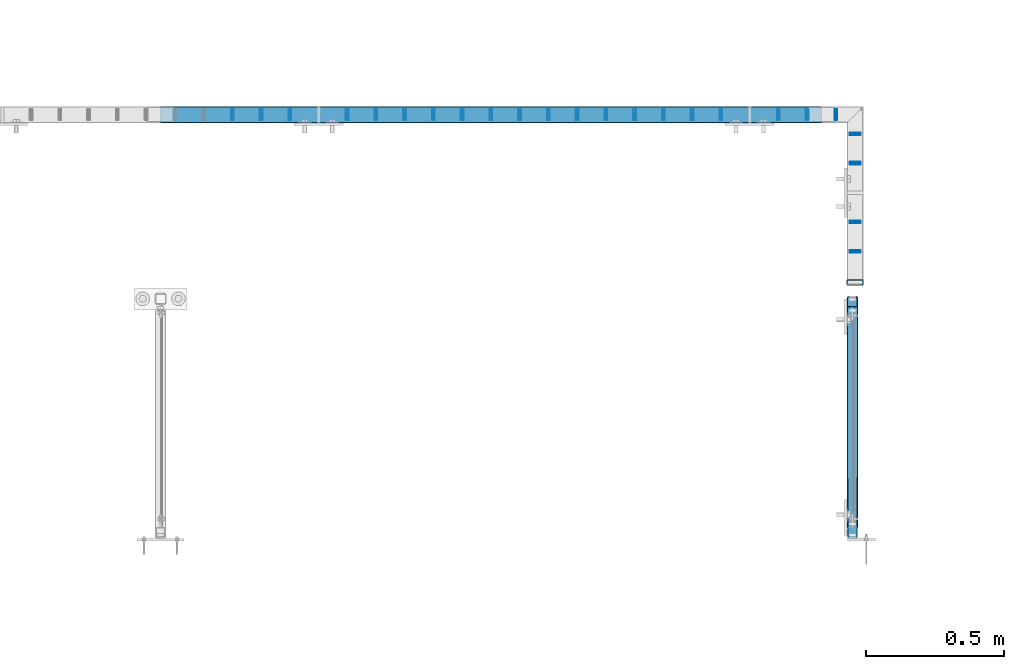
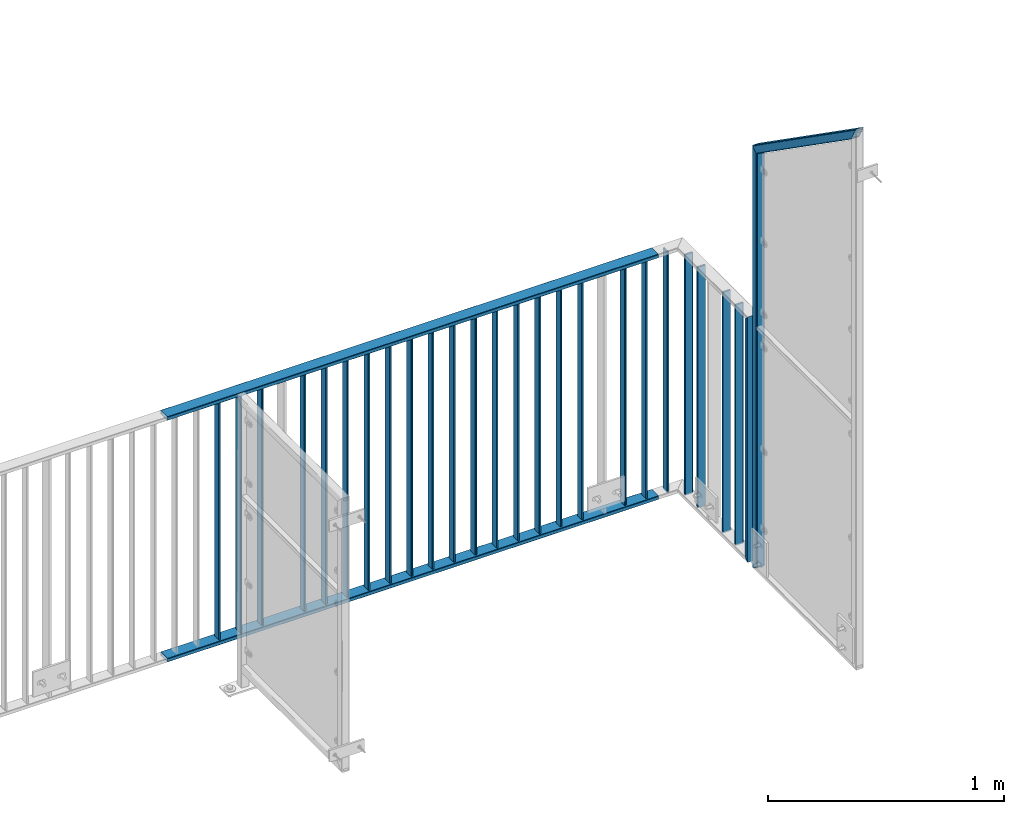
# One storey, part 28 of 156: 29 beams, 3 elements without a shape of their own.
"""IFC2X3 building model written with IfcOpenShell, lengths in millimetres."""

from ifc_helpers import new_model, si_unit, frame, origin_with_axes, origin_2d_with_axis, place, context, subcontext, project, spatial, hollow_rectangle, extrude, clip, halfspace, material, type_object, element, aggregate, save


model = new_model("IFC2X3")

# Units and contexts
model_context = context("Model", 3, precision=1e-05, world=origin_with_axes())
body_context = subcontext(model_context, "Body", "Model", "MODEL_VIEW")
ifc_project = project(units=[si_unit("LENGTHUNIT", "METRE", prefix="MILLI"), si_unit("AREAUNIT", "SQUARE_METRE"), si_unit("VOLUMEUNIT", "CUBIC_METRE"), si_unit("MASSUNIT", "GRAM", prefix="KILO"), si_unit("TIMEUNIT", "SECOND"), si_unit("PLANEANGLEUNIT", "RADIAN"), si_unit("SOLIDANGLEUNIT", "STERADIAN"), si_unit("THERMODYNAMICTEMPERATUREUNIT", "DEGREE_CELSIUS"), si_unit("LUMINOUSINTENSITYUNIT", "LUMEN")], contexts=[model_context])

# Site, building, storey
site_placement = place(None, origin_with_axes())
site = spatial("IfcSite", under=ifc_project, at=site_placement, CompositionType="ELEMENT")
building_placement = place(site_placement, origin_with_axes())
building = spatial("IfcBuilding", under=site, at=building_placement, Name="Undefined", CompositionType="ELEMENT")
storey_placement = place(building_placement, origin_with_axes())
storey = spatial("IfcBuildingStorey", under=building, at=storey_placement, Name="Undefined", CompositionType="ELEMENT", Elevation=0.0)

# Assembly, beam
assembly_1_placement = place(storey_placement, origin_with_axes())
assembly_1 = element("IfcElementAssembly", 1, at=assembly_1_placement, inside=storey, AssemblyPlace="NOTDEFINED", PredefinedType="RIGID_FRAME")
ifc_material = material(Name="STEEL/S235JR")
beam_type_1 = type_object("IfcBeamType", Name="K60/20/2", PredefinedType="NOTDEFINED")
beam_1_placement = place(assembly_1_placement, frame((36402.6741455078, 21657.9919947282, 2740.0), z_axis=(0.0, -1.0, 0.0), x_axis=(-1.0, 0.0, 0.0)))
beam_1 = element("IfcBeam", 2, at=beam_1_placement, type_object=beam_type_1, material=ifc_material, ObjectType="K60/20/2", context=body_context, shape_type="SweptSolid", body=[
    extrude(hollow_rectangle(XDim=20.0, YDim=60.0, WallThickness=2.0, InnerFilletRadius=2.0, OuterFilletRadius=4.0, at=origin_2d_with_axis()), frame((2402.72054931641, 0.0, 0.0), z_axis=(-1.0, 0.0, 0.0), x_axis=(0.0, -1.0, 0.0)), (0.0, 0.0, 1.0), 2402.72),
])

assembly_2_placement = place(storey_placement, origin_with_axes())
assembly_2 = element("IfcElementAssembly", 3, at=assembly_2_placement, inside=storey, AssemblyPlace="NOTDEFINED", PredefinedType="RIGID_FRAME")
beam_2_placement = place(assembly_2_placement, frame((36524.9961242676, 21048.0016473224, 4000.0), z_axis=(-1.0, 0.0, 0.0), x_axis=(0.0, 0.0, -1.0)))
beam_2 = element("IfcBeam", 4, at=beam_2_placement, type_object=beam_type_1, material=ifc_material, ObjectType="K60/20/2", context=body_context, shape_type="Clipping", body=[
    clip(clip(extrude(hollow_rectangle(XDim=20.0, YDim=60.0, WallThickness=2.0, InnerFilletRadius=2.0, OuterFilletRadius=4.0, at=origin_2d_with_axis()), frame((1280.2, 0.0, 0.0), z_axis=(-1.0, 0.0, 0.0), x_axis=(0.0, -1.0, 0.0)), (0.0, 0.0, 1.0), 1290.4), halfspace(frame((1270.0, 10.0, 0.0), z_axis=(0.707106781186548, -0.707106781186548, 0.0), x_axis=(0.0, 0.0, -1.0)), False)), halfspace(frame((20.0, -10.0, 0.0), z_axis=(-0.707106781186548, -0.707106781186548, 0.0), x_axis=(0.0, 0.0, -1.0)), False)),
])

# Beam
beam_3_placement = place(assembly_1_placement, frame((36402.6741455078, 21657.9919947282, 3990.0), z_axis=(0.0, -1.0, 0.0), x_axis=(-1.0, 0.0, 0.0)))
beam_3 = element("IfcBeam", 5, at=beam_3_placement, type_object=beam_type_1, material=ifc_material, ObjectType="K60/20/2", context=body_context, shape_type="SweptSolid", body=[
    extrude(hollow_rectangle(XDim=20.0, YDim=60.0, WallThickness=2.0, InnerFilletRadius=2.0, OuterFilletRadius=4.0, at=origin_2d_with_axis()), frame((2402.72054931641, 0.0, 0.0), z_axis=(-1.0, 0.0, 0.0), x_axis=(0.0, -1.0, 0.0)), (0.0, 0.0, 1.0), 2402.72),
])

beam_type_2 = type_object("IfcBeamType", Name="K40/10/1.5", PredefinedType="NOTDEFINED")
beam_4_placement = place(assembly_1_placement, frame((34679.0085961914, 21657.9919947282, 3980.00000000003), z_axis=(0.0, -1.0, 0.0), x_axis=(0.0, 0.0, -1.0)))
beam_4 = element("IfcBeam", 6, at=beam_4_placement, type_object=beam_type_2, material=ifc_material, ObjectType="K40/10/1.5", context=body_context, shape_type="Clipping", body=[
    clip(clip(extrude(hollow_rectangle(XDim=10.0, YDim=40.0, WallThickness=1.5, InnerFilletRadius=1.5, OuterFilletRadius=3.0, at=origin_2d_with_axis()), frame((1237.00000000003, 0.0, 0.0), z_axis=(-1.0, 0.0, 0.0), x_axis=(0.0, -1.0, 0.0)), (0.0, 0.0, 1.0), 1244.0), halfspace(frame((1237.00000000003, 4.34248751949781, 47.3810900558092), z_axis=(1.0, 0.0, 0.0), x_axis=(0.0, -0.768354814194188, -0.640024124158313)), False)), halfspace(frame((-6.99999999997453, -4.34248751950508, 47.3810900558092), z_axis=(-1.0, 0.0, 0.0), x_axis=(0.0, 0.7683548141934, -0.640024124159258)), False)),
])

beam_5_placement = place(assembly_1_placement, frame((36246.0585961914, 21657.9919947282, 3980.00000000003), z_axis=(0.0, -1.0, 0.0), x_axis=(0.0, 0.0, -1.0)))
beam_5 = element("IfcBeam", 7, at=beam_5_placement, type_object=beam_type_2, material=ifc_material, ObjectType="K40/10/1.5", context=body_context, shape_type="Clipping", body=[
    clip(clip(extrude(hollow_rectangle(XDim=10.0, YDim=40.0, WallThickness=1.5, InnerFilletRadius=1.5, OuterFilletRadius=3.0, at=origin_2d_with_axis()), frame((1237.00000000003, 0.0, 0.0), z_axis=(-1.0, 0.0, 0.0), x_axis=(0.0, -1.0, 0.0)), (0.0, 0.0, 1.0), 1244.0), halfspace(frame((1237.00000000003, 4.34248751949781, 47.3810900558092), z_axis=(1.0, 0.0, 0.0), x_axis=(0.0, -0.768354814194188, -0.640024124158313)), False)), halfspace(frame((-6.99999999997453, -4.34248751950508, 47.3810900558092), z_axis=(-1.0, 0.0, 0.0), x_axis=(0.0, 0.7683548141934, -0.640024124159258)), False)),
])

beam_6_placement = place(assembly_1_placement, frame((34261.1285961914, 21657.9919947282, 3980.00000000003), z_axis=(0.0, -1.0, 0.0), x_axis=(0.0, 0.0, -1.0)))
beam_6 = element("IfcBeam", 8, at=beam_6_placement, type_object=beam_type_2, material=ifc_material, ObjectType="K40/10/1.5", context=body_context, shape_type="Clipping", body=[
    clip(clip(extrude(hollow_rectangle(XDim=10.0, YDim=40.0, WallThickness=1.5, InnerFilletRadius=1.5, OuterFilletRadius=3.0, at=origin_2d_with_axis()), frame((1237.00000000003, 0.0, 0.0), z_axis=(-1.0, 0.0, 0.0), x_axis=(0.0, -1.0, 0.0)), (0.0, 0.0, 1.0), 1244.0), halfspace(frame((1237.00000000003, 4.34248751949781, 47.3810900558092), z_axis=(1.0, 0.0, 0.0), x_axis=(0.0, -0.768354814194188, -0.640024124158313)), False)), halfspace(frame((-6.99999999997453, -4.34248751950508, 47.3810900558092), z_axis=(-1.0, 0.0, 0.0), x_axis=(0.0, 0.7683548141934, -0.640024124159258)), False)),
])

beam_7_placement = place(assembly_1_placement, frame((34365.5985961914, 21657.9919947282, 3980.00000000003), z_axis=(0.0, -1.0, 0.0), x_axis=(0.0, 0.0, -1.0)))
beam_7 = element("IfcBeam", 9, at=beam_7_placement, type_object=beam_type_2, material=ifc_material, ObjectType="K40/10/1.5", context=body_context, shape_type="Clipping", body=[
    clip(clip(extrude(hollow_rectangle(XDim=10.0, YDim=40.0, WallThickness=1.5, InnerFilletRadius=1.5, OuterFilletRadius=3.0, at=origin_2d_with_axis()), frame((1237.00000000003, 0.0, 0.0), z_axis=(-1.0, 0.0, 0.0), x_axis=(0.0, -1.0, 0.0)), (0.0, 0.0, 1.0), 1244.0), halfspace(frame((1237.00000000003, 4.34248751949781, 47.3810900558092), z_axis=(1.0, 0.0, 0.0), x_axis=(0.0, -0.768354814194188, -0.640024124158313)), False)), halfspace(frame((-6.99999999997453, -4.34248751950508, 47.3810900558092), z_axis=(-1.0, 0.0, 0.0), x_axis=(0.0, 0.7683548141934, -0.640024124159258)), False)),
])

beam_8_placement = place(assembly_1_placement, frame((34470.0685961914, 21657.9919947282, 3980.00000000003), z_axis=(0.0, -1.0, 0.0), x_axis=(0.0, 0.0, -1.0)))
beam_8 = element("IfcBeam", 10, at=beam_8_placement, type_object=beam_type_2, material=ifc_material, ObjectType="K40/10/1.5", context=body_context, shape_type="Clipping", body=[
    clip(clip(extrude(hollow_rectangle(XDim=10.0, YDim=40.0, WallThickness=1.5, InnerFilletRadius=1.5, OuterFilletRadius=3.0, at=origin_2d_with_axis()), frame((1237.00000000003, 0.0, 0.0), z_axis=(-1.0, 0.0, 0.0), x_axis=(0.0, -1.0, 0.0)), (0.0, 0.0, 1.0), 1244.0), halfspace(frame((1237.00000000003, 4.34248751949781, 47.3810900558092), z_axis=(1.0, 0.0, 0.0), x_axis=(0.0, -0.768354814194188, -0.640024124158313)), False)), halfspace(frame((-6.99999999997453, -4.34248751950508, 47.3810900558092), z_axis=(-1.0, 0.0, 0.0), x_axis=(0.0, 0.7683548141934, -0.640024124159258)), False)),
])

beam_9_placement = place(assembly_1_placement, frame((34783.4785961914, 21657.9919947282, 3980.00000000003), z_axis=(0.0, -1.0, 0.0), x_axis=(0.0, 0.0, -1.0)))
beam_9 = element("IfcBeam", 11, at=beam_9_placement, type_object=beam_type_2, material=ifc_material, ObjectType="K40/10/1.5", context=body_context, shape_type="Clipping", body=[
    clip(clip(extrude(hollow_rectangle(XDim=10.0, YDim=40.0, WallThickness=1.5, InnerFilletRadius=1.5, OuterFilletRadius=3.0, at=origin_2d_with_axis()), frame((1237.00000000003, 0.0, 0.0), z_axis=(-1.0, 0.0, 0.0), x_axis=(0.0, -1.0, 0.0)), (0.0, 0.0, 1.0), 1244.0), halfspace(frame((1237.00000000003, 4.34248751949781, 47.3810900558092), z_axis=(1.0, 0.0, 0.0), x_axis=(0.0, -0.768354814194188, -0.640024124158313)), False)), halfspace(frame((-6.99999999997453, -4.34248751950508, 47.3810900558092), z_axis=(-1.0, 0.0, 0.0), x_axis=(0.0, 0.7683548141934, -0.640024124159258)), False)),
])

beam_10_placement = place(assembly_1_placement, frame((34887.9485961914, 21657.9919947282, 3980.00000000003), z_axis=(0.0, -1.0, 0.0), x_axis=(0.0, 0.0, -1.0)))
beam_10 = element("IfcBeam", 12, at=beam_10_placement, type_object=beam_type_2, material=ifc_material, ObjectType="K40/10/1.5", context=body_context, shape_type="Clipping", body=[
    clip(clip(extrude(hollow_rectangle(XDim=10.0, YDim=40.0, WallThickness=1.5, InnerFilletRadius=1.5, OuterFilletRadius=3.0, at=origin_2d_with_axis()), frame((1237.00000000003, 0.0, 0.0), z_axis=(-1.0, 0.0, 0.0), x_axis=(0.0, -1.0, 0.0)), (0.0, 0.0, 1.0), 1244.0), halfspace(frame((1237.00000000003, 4.34248751949781, 47.3810900558092), z_axis=(1.0, 0.0, 0.0), x_axis=(0.0, -0.768354814194188, -0.640024124158313)), False)), halfspace(frame((-6.99999999997453, -4.34248751950508, 47.3810900558092), z_axis=(-1.0, 0.0, 0.0), x_axis=(0.0, 0.7683548141934, -0.640024124159258)), False)),
])

beam_11_placement = place(assembly_1_placement, frame((34992.4185961914, 21657.9919947282, 3980.00000000003), z_axis=(0.0, -1.0, 0.0), x_axis=(0.0, 0.0, -1.0)))
beam_11 = element("IfcBeam", 13, at=beam_11_placement, type_object=beam_type_2, material=ifc_material, ObjectType="K40/10/1.5", context=body_context, shape_type="Clipping", body=[
    clip(clip(extrude(hollow_rectangle(XDim=10.0, YDim=40.0, WallThickness=1.5, InnerFilletRadius=1.5, OuterFilletRadius=3.0, at=origin_2d_with_axis()), frame((1237.00000000003, 0.0, 0.0), z_axis=(-1.0, 0.0, 0.0), x_axis=(0.0, -1.0, 0.0)), (0.0, 0.0, 1.0), 1244.0), halfspace(frame((1237.00000000003, 4.34248751949781, 47.3810900558092), z_axis=(1.0, 0.0, 0.0), x_axis=(0.0, -0.768354814194188, -0.640024124158313)), False)), halfspace(frame((-6.99999999997453, -4.34248751950508, 47.3810900558092), z_axis=(-1.0, 0.0, 0.0), x_axis=(0.0, 0.7683548141934, -0.640024124159258)), False)),
])

beam_12_placement = place(assembly_1_placement, frame((35096.8885961914, 21657.9919947282, 3980.00000000003), z_axis=(0.0, -1.0, 0.0), x_axis=(0.0, 0.0, -1.0)))
beam_12 = element("IfcBeam", 14, at=beam_12_placement, type_object=beam_type_2, material=ifc_material, ObjectType="K40/10/1.5", context=body_context, shape_type="Clipping", body=[
    clip(clip(extrude(hollow_rectangle(XDim=10.0, YDim=40.0, WallThickness=1.5, InnerFilletRadius=1.5, OuterFilletRadius=3.0, at=origin_2d_with_axis()), frame((1237.00000000003, 0.0, 0.0), z_axis=(-1.0, 0.0, 0.0), x_axis=(0.0, -1.0, 0.0)), (0.0, 0.0, 1.0), 1244.0), halfspace(frame((1237.00000000003, 4.34248751949781, 47.3810900558092), z_axis=(1.0, 0.0, 0.0), x_axis=(0.0, -0.768354814194188, -0.640024124158313)), False)), halfspace(frame((-6.99999999997453, -4.34248751950508, 47.3810900558092), z_axis=(-1.0, 0.0, 0.0), x_axis=(0.0, 0.7683548141934, -0.640024124159258)), False)),
])

beam_13_placement = place(assembly_1_placement, frame((35201.3585961914, 21657.9919947282, 3980.00000000003), z_axis=(0.0, -1.0, 0.0), x_axis=(0.0, 0.0, -1.0)))
beam_13 = element("IfcBeam", 15, at=beam_13_placement, type_object=beam_type_2, material=ifc_material, ObjectType="K40/10/1.5", context=body_context, shape_type="Clipping", body=[
    clip(clip(extrude(hollow_rectangle(XDim=10.0, YDim=40.0, WallThickness=1.5, InnerFilletRadius=1.5, OuterFilletRadius=3.0, at=origin_2d_with_axis()), frame((1237.00000000003, 0.0, 0.0), z_axis=(-1.0, 0.0, 0.0), x_axis=(0.0, -1.0, 0.0)), (0.0, 0.0, 1.0), 1244.0), halfspace(frame((1237.00000000003, 4.34248751949781, 47.3810900558092), z_axis=(1.0, 0.0, 0.0), x_axis=(0.0, -0.768354814194188, -0.640024124158313)), False)), halfspace(frame((-6.99999999997453, -4.34248751950508, 47.3810900558092), z_axis=(-1.0, 0.0, 0.0), x_axis=(0.0, 0.7683548141934, -0.640024124159258)), False)),
])

beam_14_placement = place(assembly_1_placement, frame((35305.8285961914, 21657.9919947282, 3980.00000000003), z_axis=(0.0, -1.0, 0.0), x_axis=(0.0, 0.0, -1.0)))
beam_14 = element("IfcBeam", 16, at=beam_14_placement, type_object=beam_type_2, material=ifc_material, ObjectType="K40/10/1.5", context=body_context, shape_type="Clipping", body=[
    clip(clip(extrude(hollow_rectangle(XDim=10.0, YDim=40.0, WallThickness=1.5, InnerFilletRadius=1.5, OuterFilletRadius=3.0, at=origin_2d_with_axis()), frame((1237.00000000003, 0.0, 0.0), z_axis=(-1.0, 0.0, 0.0), x_axis=(0.0, -1.0, 0.0)), (0.0, 0.0, 1.0), 1244.0), halfspace(frame((1237.00000000003, 4.34248751949781, 47.3810900558092), z_axis=(1.0, 0.0, 0.0), x_axis=(0.0, -0.768354814194188, -0.640024124158313)), False)), halfspace(frame((-6.99999999997453, -4.34248751950508, 47.3810900558092), z_axis=(-1.0, 0.0, 0.0), x_axis=(0.0, 0.7683548141934, -0.640024124159258)), False)),
])

beam_15_placement = place(assembly_1_placement, frame((35410.2985961914, 21657.9919947282, 3980.00000000003), z_axis=(0.0, -1.0, 0.0), x_axis=(0.0, 0.0, -1.0)))
beam_15 = element("IfcBeam", 17, at=beam_15_placement, type_object=beam_type_2, material=ifc_material, ObjectType="K40/10/1.5", context=body_context, shape_type="Clipping", body=[
    clip(clip(extrude(hollow_rectangle(XDim=10.0, YDim=40.0, WallThickness=1.5, InnerFilletRadius=1.5, OuterFilletRadius=3.0, at=origin_2d_with_axis()), frame((1237.00000000003, 0.0, 0.0), z_axis=(-1.0, 0.0, 0.0), x_axis=(0.0, -1.0, 0.0)), (0.0, 0.0, 1.0), 1244.0), halfspace(frame((1237.00000000003, 4.34248751949781, 47.3810900558092), z_axis=(1.0, 0.0, 0.0), x_axis=(0.0, -0.768354814194188, -0.640024124158313)), False)), halfspace(frame((-6.99999999997453, -4.34248751950508, 47.3810900558092), z_axis=(-1.0, 0.0, 0.0), x_axis=(0.0, 0.7683548141934, -0.640024124159258)), False)),
])

beam_16_placement = place(assembly_1_placement, frame((35514.7685961914, 21657.9919947282, 3980.00000000003), z_axis=(0.0, -1.0, 0.0), x_axis=(0.0, 0.0, -1.0)))
beam_16 = element("IfcBeam", 18, at=beam_16_placement, type_object=beam_type_2, material=ifc_material, ObjectType="K40/10/1.5", context=body_context, shape_type="Clipping", body=[
    clip(clip(extrude(hollow_rectangle(XDim=10.0, YDim=40.0, WallThickness=1.5, InnerFilletRadius=1.5, OuterFilletRadius=3.0, at=origin_2d_with_axis()), frame((1237.00000000003, 0.0, 0.0), z_axis=(-1.0, 0.0, 0.0), x_axis=(0.0, -1.0, 0.0)), (0.0, 0.0, 1.0), 1244.0), halfspace(frame((1237.00000000003, 4.34248751949781, 47.3810900558092), z_axis=(1.0, 0.0, 0.0), x_axis=(0.0, -0.768354814194188, -0.640024124158313)), False)), halfspace(frame((-6.99999999997453, -4.34248751950508, 47.3810900558092), z_axis=(-1.0, 0.0, 0.0), x_axis=(0.0, 0.7683548141934, -0.640024124159258)), False)),
])

beam_17_placement = place(assembly_1_placement, frame((35619.2385961914, 21657.9919947282, 3980.00000000003), z_axis=(0.0, -1.0, 0.0), x_axis=(0.0, 0.0, -1.0)))
beam_17 = element("IfcBeam", 19, at=beam_17_placement, type_object=beam_type_2, material=ifc_material, ObjectType="K40/10/1.5", context=body_context, shape_type="Clipping", body=[
    clip(clip(extrude(hollow_rectangle(XDim=10.0, YDim=40.0, WallThickness=1.5, InnerFilletRadius=1.5, OuterFilletRadius=3.0, at=origin_2d_with_axis()), frame((1237.00000000003, 0.0, 0.0), z_axis=(-1.0, 0.0, 0.0), x_axis=(0.0, -1.0, 0.0)), (0.0, 0.0, 1.0), 1244.0), halfspace(frame((1237.00000000003, 4.34248751949781, 47.3810900558092), z_axis=(1.0, 0.0, 0.0), x_axis=(0.0, -0.768354814194188, -0.640024124158313)), False)), halfspace(frame((-6.99999999997453, -4.34248751950508, 47.3810900558092), z_axis=(-1.0, 0.0, 0.0), x_axis=(0.0, 0.7683548141934, -0.640024124159258)), False)),
])

beam_18_placement = place(assembly_1_placement, frame((35723.7085961914, 21657.9919947282, 3980.00000000003), z_axis=(0.0, -1.0, 0.0), x_axis=(0.0, 0.0, -1.0)))
beam_18 = element("IfcBeam", 20, at=beam_18_placement, type_object=beam_type_2, material=ifc_material, ObjectType="K40/10/1.5", context=body_context, shape_type="Clipping", body=[
    clip(clip(extrude(hollow_rectangle(XDim=10.0, YDim=40.0, WallThickness=1.5, InnerFilletRadius=1.5, OuterFilletRadius=3.0, at=origin_2d_with_axis()), frame((1237.00000000003, 0.0, 0.0), z_axis=(-1.0, 0.0, 0.0), x_axis=(0.0, -1.0, 0.0)), (0.0, 0.0, 1.0), 1244.0), halfspace(frame((1237.00000000003, 4.34248751949781, 47.3810900558092), z_axis=(1.0, 0.0, 0.0), x_axis=(0.0, -0.768354814194188, -0.640024124158313)), False)), halfspace(frame((-6.99999999997453, -4.34248751950508, 47.3810900558092), z_axis=(-1.0, 0.0, 0.0), x_axis=(0.0, 0.7683548141934, -0.640024124159258)), False)),
])

beam_19_placement = place(assembly_1_placement, frame((35828.1785961914, 21657.9919947282, 3980.00000000003), z_axis=(0.0, -1.0, 0.0), x_axis=(0.0, 0.0, -1.0)))
beam_19 = element("IfcBeam", 21, at=beam_19_placement, type_object=beam_type_2, material=ifc_material, ObjectType="K40/10/1.5", context=body_context, shape_type="Clipping", body=[
    clip(clip(extrude(hollow_rectangle(XDim=10.0, YDim=40.0, WallThickness=1.5, InnerFilletRadius=1.5, OuterFilletRadius=3.0, at=origin_2d_with_axis()), frame((1237.00000000003, 0.0, 0.0), z_axis=(-1.0, 0.0, 0.0), x_axis=(0.0, -1.0, 0.0)), (0.0, 0.0, 1.0), 1244.0), halfspace(frame((1237.00000000003, 4.34248751949781, 47.3810900558092), z_axis=(1.0, 0.0, 0.0), x_axis=(0.0, -0.768354814194188, -0.640024124158313)), False)), halfspace(frame((-6.99999999997453, -4.34248751950508, 47.3810900558092), z_axis=(-1.0, 0.0, 0.0), x_axis=(0.0, 0.7683548141934, -0.640024124159258)), False)),
])

beam_20_placement = place(assembly_1_placement, frame((35932.6485961914, 21657.9919947282, 3980.00000000003), z_axis=(0.0, -1.0, 0.0), x_axis=(0.0, 0.0, -1.0)))
beam_20 = element("IfcBeam", 22, at=beam_20_placement, type_object=beam_type_2, material=ifc_material, ObjectType="K40/10/1.5", context=body_context, shape_type="Clipping", body=[
    clip(clip(extrude(hollow_rectangle(XDim=10.0, YDim=40.0, WallThickness=1.5, InnerFilletRadius=1.5, OuterFilletRadius=3.0, at=origin_2d_with_axis()), frame((1237.00000000003, 0.0, 0.0), z_axis=(-1.0, 0.0, 0.0), x_axis=(0.0, -1.0, 0.0)), (0.0, 0.0, 1.0), 1244.0), halfspace(frame((1237.00000000003, 4.34248751949781, 47.3810900558092), z_axis=(1.0, 0.0, 0.0), x_axis=(0.0, -0.768354814194188, -0.640024124158313)), False)), halfspace(frame((-6.99999999997453, -4.34248751950508, 47.3810900558092), z_axis=(-1.0, 0.0, 0.0), x_axis=(0.0, 0.7683548141934, -0.640024124159258)), False)),
])

beam_21_placement = place(assembly_1_placement, frame((36037.1185961914, 21657.9919947282, 3980.00000000003), z_axis=(0.0, -1.0, 0.0), x_axis=(0.0, 0.0, -1.0)))
beam_21 = element("IfcBeam", 23, at=beam_21_placement, type_object=beam_type_2, material=ifc_material, ObjectType="K40/10/1.5", context=body_context, shape_type="Clipping", body=[
    clip(clip(extrude(hollow_rectangle(XDim=10.0, YDim=40.0, WallThickness=1.5, InnerFilletRadius=1.5, OuterFilletRadius=3.0, at=origin_2d_with_axis()), frame((1237.00000000003, 0.0, 0.0), z_axis=(-1.0, 0.0, 0.0), x_axis=(0.0, -1.0, 0.0)), (0.0, 0.0, 1.0), 1244.0), halfspace(frame((1237.00000000003, 4.34248751949781, 47.3810900558092), z_axis=(1.0, 0.0, 0.0), x_axis=(0.0, -0.768354814194188, -0.640024124158313)), False)), halfspace(frame((-6.99999999997453, -4.34248751950508, 47.3810900558092), z_axis=(-1.0, 0.0, 0.0), x_axis=(0.0, 0.7683548141934, -0.640024124159258)), False)),
])

beam_22_placement = place(assembly_1_placement, frame((36350.5285961914, 21657.9919947282, 3980.00000000003), z_axis=(0.0, -1.0, 0.0), x_axis=(0.0, 0.0, -1.0)))
beam_22 = element("IfcBeam", 24, at=beam_22_placement, type_object=beam_type_2, material=ifc_material, ObjectType="K40/10/1.5", context=body_context, shape_type="Clipping", body=[
    clip(clip(extrude(hollow_rectangle(XDim=10.0, YDim=40.0, WallThickness=1.5, InnerFilletRadius=1.5, OuterFilletRadius=3.0, at=origin_2d_with_axis()), frame((1237.00000000003, 0.0, 0.0), z_axis=(-1.0, 0.0, 0.0), x_axis=(0.0, -1.0, 0.0)), (0.0, 0.0, 1.0), 1244.0), halfspace(frame((1237.00000000003, 4.28697690345871, 47.3348312091512), z_axis=(1.0, 0.0, 0.0), x_axis=(0.0, -0.763991285051099, -0.645226562043109)), False)), halfspace(frame((-6.99999999997453, -4.28697690345871, 47.3348312091512), z_axis=(-1.0, 0.0, 0.0), x_axis=(0.0, 0.763991285051099, -0.645226562043109)), False)),
])

aggregate(assembly_1, [beam_1, beam_4, beam_5, beam_6, beam_7, beam_8, beam_9, beam_10, beam_11, beam_12, beam_13, beam_14, beam_15, beam_16, beam_17, beam_18, beam_19, beam_20, beam_21, beam_22, beam_3])

beam_23_placement = place(assembly_2_placement, frame((36524.9982833167, 21160.3107649865, 3980.00000000003), z_axis=(-1.0, 0.0, 0.0), x_axis=(0.0, 0.0, -1.0)))
beam_23 = element("IfcBeam", 25, at=beam_23_placement, type_object=beam_type_2, material=ifc_material, ObjectType="K40/10/1.5", context=body_context, shape_type="Clipping", body=[
    clip(clip(extrude(hollow_rectangle(XDim=10.0, YDim=40.0, WallThickness=1.5, InnerFilletRadius=1.5, OuterFilletRadius=3.0, at=origin_2d_with_axis()), frame((1237.00000000003, 0.0, 0.0), z_axis=(-1.0, 0.0, 0.0), x_axis=(0.0, -1.0, 0.0)), (0.0, 0.0, 1.0), 1244.0), halfspace(frame((1237.00000000003, 3.63803898150218, 46.7940496082883), z_axis=(1.0, 0.0, 0.0), x_axis=(0.0, -0.758923924280425, -0.65117929724063)), False)), halfspace(frame((-6.99999999997453, -3.24498419219526, 46.4665039507308), z_axis=(-1.0, 0.0, 0.0), x_axis=(0.0, 0.75441426312288, -0.656398598106944)), False)),
])

beam_24_placement = place(assembly_2_placement, frame((36524.9982833167, 21267.2307649865, 3980.00000000003), z_axis=(-1.0, 0.0, 0.0), x_axis=(0.0, 0.0, -1.0)))
beam_24 = element("IfcBeam", 26, at=beam_24_placement, type_object=beam_type_2, material=ifc_material, ObjectType="K40/10/1.5", context=body_context, shape_type="Clipping", body=[
    clip(clip(extrude(hollow_rectangle(XDim=10.0, YDim=40.0, WallThickness=1.5, InnerFilletRadius=1.5, OuterFilletRadius=3.0, at=origin_2d_with_axis()), frame((1237.00000000003, 0.0, 0.0), z_axis=(-1.0, 0.0, 0.0), x_axis=(0.0, -1.0, 0.0)), (0.0, 0.0, 1.0), 1244.0), halfspace(frame((1237.00000000003, 3.2449841921989, 46.4665039507236), z_axis=(1.0, 0.0, 0.0), x_axis=(0.0, -0.754414263122933, -0.656398598106883)), False)), halfspace(frame((-6.99999999997453, -3.24498419219526, 46.4665039507308), z_axis=(-1.0, 0.0, 0.0), x_axis=(0.0, 0.75441426312288, -0.656398598106944)), False)),
])

beam_25_placement = place(assembly_2_placement, frame((36524.9982833167, 21481.0707649865, 3980.00000000003), z_axis=(-1.0, 0.0, 0.0), x_axis=(0.0, 0.0, -1.0)))
beam_25 = element("IfcBeam", 27, at=beam_25_placement, type_object=beam_type_2, material=ifc_material, ObjectType="K40/10/1.5", context=body_context, shape_type="Clipping", body=[
    clip(clip(extrude(hollow_rectangle(XDim=10.0, YDim=40.0, WallThickness=1.5, InnerFilletRadius=1.5, OuterFilletRadius=3.0, at=origin_2d_with_axis()), frame((1237.00000000003, 0.0, 0.0), z_axis=(-1.0, 0.0, 0.0), x_axis=(0.0, -1.0, 0.0)), (0.0, 0.0, 1.0), 1244.0), halfspace(frame((1237.00000000003, 3.2449841921989, 46.4665039507236), z_axis=(1.0, 0.0, 0.0), x_axis=(0.0, -0.754414263122933, -0.656398598106883)), False)), halfspace(frame((-6.99999999997453, -3.24498419219526, 46.4665039507308), z_axis=(-1.0, 0.0, 0.0), x_axis=(0.0, 0.75441426312288, -0.656398598106944)), False)),
])

beam_26_placement = place(assembly_2_placement, frame((36454.9985961914, 21657.9919947282, 3980.00000000003), z_axis=(0.0, -1.0, 0.0), x_axis=(0.0, 0.0, -1.0)))
beam_26 = element("IfcBeam", 28, at=beam_26_placement, type_object=beam_type_2, material=ifc_material, ObjectType="K40/10/1.5", context=body_context, shape_type="Clipping", body=[
    clip(clip(extrude(hollow_rectangle(XDim=10.0, YDim=40.0, WallThickness=1.5, InnerFilletRadius=1.5, OuterFilletRadius=3.0, at=origin_2d_with_axis()), frame((1237.00000000003, 0.0, 0.0), z_axis=(-1.0, 0.0, 0.0), x_axis=(0.0, -1.0, 0.0)), (0.0, 0.0, 1.0), 1244.0), halfspace(frame((1237.00000000003, 4.34248751949781, 47.3810900558092), z_axis=(1.0, 0.0, 0.0), x_axis=(0.0, -0.766598961667631, -0.642126180723158)), False)), halfspace(frame((-6.99999999997453, -4.34248751950508, 47.3810900558092), z_axis=(-1.0, 0.0, 0.0), x_axis=(0.0, 0.766598961668776, -0.642126180721792)), False)),
])

beam_27_placement = place(assembly_2_placement, frame((36524.9982833167, 21587.9907649865, 3980.00000000003), z_axis=(-1.0, 0.0, 0.0), x_axis=(0.0, 0.0, -1.0)))
beam_27 = element("IfcBeam", 29, at=beam_27_placement, type_object=beam_type_2, material=ifc_material, ObjectType="K40/10/1.5", context=body_context, shape_type="Clipping", body=[
    clip(clip(extrude(hollow_rectangle(XDim=10.0, YDim=40.0, WallThickness=1.5, InnerFilletRadius=1.5, OuterFilletRadius=3.0, at=origin_2d_with_axis()), frame((1237.00000000003, 0.0, 0.0), z_axis=(-1.0, 0.0, 0.0), x_axis=(0.0, -1.0, 0.0)), (0.0, 0.0, 1.0), 1244.0), halfspace(frame((1237.00000000003, 2.66359292875859, 45.9820112315028), z_axis=(1.0, 0.0, 0.0), x_axis=(0.0, -0.747680594278991, -0.664058528247785)), False)), halfspace(frame((-6.99999999997453, -2.66359292875859, 45.9820112315028), z_axis=(-1.0, 0.0, 0.0), x_axis=(0.0, 0.747680594279002, -0.664058528247773)), False)),
])

aggregate(assembly_2, [beam_23, beam_24, beam_25, beam_26, beam_2, beam_27])

# Assembly, beams
assembly_3_placement = place(storey_placement, origin_with_axes())
assembly_3 = element("IfcElementAssembly", 30, at=assembly_3_placement, inside=storey, AssemblyPlace="NOTDEFINED", PredefinedType="RIGID_FRAME")
beam_type_3 = type_object("IfcBeamType", Name="K40/3", PredefinedType="NOTDEFINED")
beam_28_placement = place(assembly_3_placement, frame((36514.9961242676, 20096.5321927629, 5520.15365547741), z_axis=(0.0, 0.573576519196191, 0.819151986280191), x_axis=(0.0, 0.81915198628019, -0.573576519196192)))
beam_28 = element("IfcBeam", 31, at=beam_28_placement, type_object=beam_type_3, material=ifc_material, ObjectType="K40/3", context=body_context, shape_type="Clipping", body=[
    clip(clip(extrude(hollow_rectangle(XDim=40.0, YDim=40.0, WallThickness=3.0, InnerFilletRadius=3.0, OuterFilletRadius=6.0, at=origin_2d_with_axis()), frame((1137.4595634918, 0.0, 0.0), z_axis=(-1.0, 0.0, 0.0), x_axis=(0.0, -1.0, 0.0)), (0.0, 0.0, 1.0), 1148.21), halfspace(frame((1086.4887579936, 0.0, 20.0000000033942), z_axis=(0.887011256109767, 0.0, -0.461747800790186), x_axis=(0.0, 1.0, 0.0)), False)), halfspace(frame((12.2077467483559, 0.0, 20.0000000013606), z_axis=(0.461748568874198, 0.0, 0.88701085627101), x_axis=(0.0, 1.0, 0.0)), True)),
])
beam_29_placement = place(assembly_3_placement, frame((36514.9961242676, 20978.0031127103, 4933.35224486177), z_axis=(1.0, 0.0, 0.0), x_axis=(0.0, 1.73100000029081e-06, -0.999999999998502)))
beam_29 = element("IfcBeam", 32, at=beam_29_placement, type_object=beam_type_3, material=ifc_material, ObjectType="K40/3", context=body_context, shape_type="Clipping", body=[
    clip(clip(extrude(hollow_rectangle(XDim=40.0, YDim=40.0, WallThickness=3.0, InnerFilletRadius=3.0, OuterFilletRadius=6.0, at=origin_2d_with_axis()), frame((2213.96778066274, 0.0, 0.0), z_axis=(-1.0, 0.0, 0.0), x_axis=(0.0, -1.0, 0.0)), (0.0, 0.0, 1.0), 2204.17), halfspace(frame((2183.35221024504, -19.999999997337, 0.0), z_axis=(-0.894426571672334, 0.447214834152978, 0.0), x_axis=(0.0, 0.0, -1.0)), True)), halfspace(frame((20.000024231771, 20.00000000004, 0.0), z_axis=(0.887011256231877, 0.461747800555614, 0.0), x_axis=(0.0, 0.0, -1.0)), True)),
])
aggregate(assembly_3, [beam_28, beam_29])

save(model, "model.ifc")
